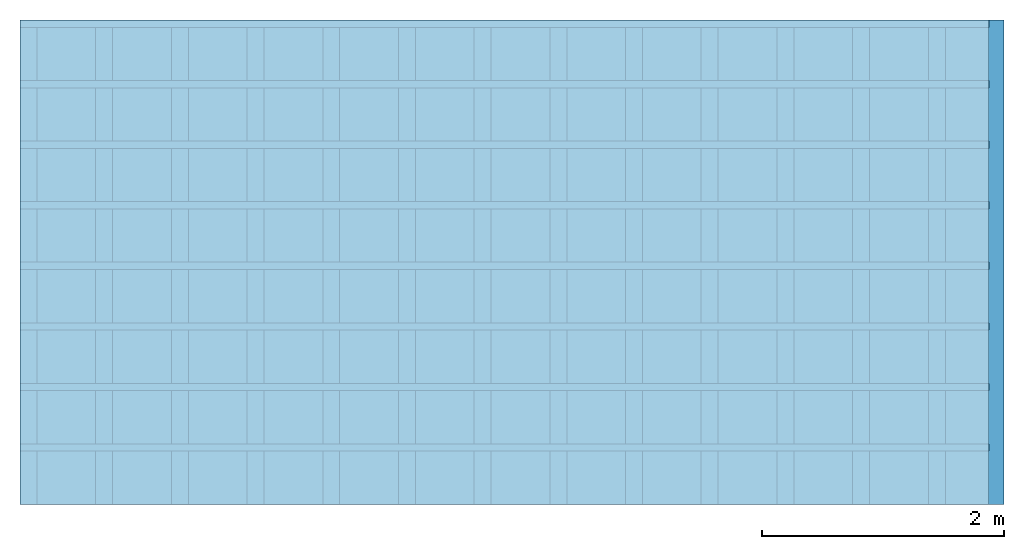
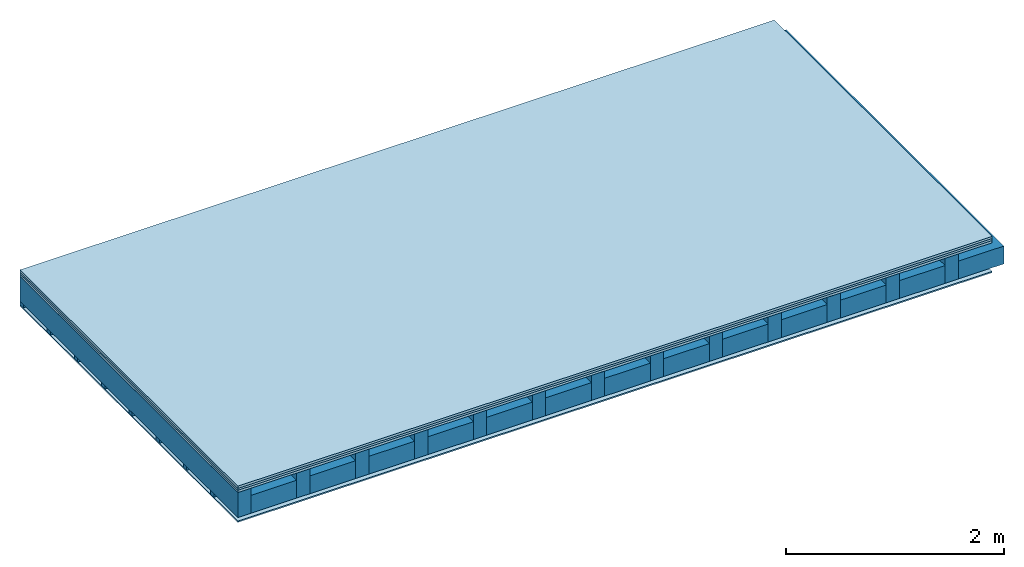
# One storey: 4 plates, 3 members, 1 element without a shape of its own.
"""IFC4 building model written with IfcOpenShell, lengths in metres."""

from ifc_helpers import new_model, si_unit, derived_unit, direction, frame, frame_2d, origin, origin_with_axes, place, context, project, spatial, rectangle, extrude, material, layer, layer_set, type_object, element, aggregate, save


model = new_model("IFC4")

# Units and contexts
plan_context = context("Plan", 3, precision=1e-05, world=origin(), true_north=direction((0.0, 1.0)))
model_context = context("Model", 3, precision=1e-05, world=origin(), true_north=direction((0.0, 1.0)))
ifc_project = project(units=[si_unit("LENGTHUNIT", "METRE"), derived_unit("SOUNDPRESSUREUNIT", [(si_unit("PRESSUREUNIT", "PASCAL", prefix="MICRO"), 0)]), si_unit("ENERGYUNIT", "JOULE", prefix="MEGA"), si_unit("MASSUNIT", "GRAM", prefix="KILO"), derived_unit("THERMALTRANSMITTANCEUNIT", [(si_unit("POWERUNIT", "WATT"), 1), (si_unit("AREAUNIT", "SQUARE_METRE"), -1), (si_unit("THERMODYNAMICTEMPERATUREUNIT", "KELVIN"), -1)]), derived_unit("AREADENSITYUNIT", [(si_unit("MASSUNIT", "GRAM", prefix="KILO"), 1), (si_unit("AREAUNIT", "SQUARE_METRE"), -1)]), derived_unit("USERDEFINED", [(si_unit("ENERGYUNIT", "JOULE", prefix="MEGA"), 1), (si_unit("AREAUNIT", "SQUARE_METRE"), -1)])], contexts=[plan_context, model_context])

# Site, building, storey
site = spatial("IfcSite", under=ifc_project)
building_placement = place(None, origin())
building = spatial("IfcBuilding", under=site, at=building_placement)
storey_placement = place(building_placement, origin())
storey = spatial("IfcBuildingStorey", under=building, at=storey_placement)

# Slab, members, plates
ifc_material_1 = material(Name="Floor heating system Therm38 longitudinal", Category="03.007")
ifc_layer_1 = layer(ifc_material_1, 0.025, Name="On-material")
ifc_material_2 = material(Category="10.009")
ifc_layer_2 = layer(ifc_material_2, 0.022, Name="Impact sound insulation")
ifc_material_3 = material(Category="07.001")
ifc_layer_3 = layer(ifc_material_3, 0.025, Name="Sub-floor")
ifc_material_4 = material(Name="of the art")
ifc_layer_4 = layer(ifc_material_4, 0.0, Name="Bond")
ifc_layer_5 = layer(None, 0.28, Name="Supporting structure")
ifc_layer_6 = layer(ifc_material_4, 0.0, Name="Bond")
ifc_layer_7 = layer(None, 0.04, Name="Battens / profiles")
ifc_material_5 = material(Category="03.007")
ifc_layer_8 = layer(ifc_material_5, 0.015, Name="Ceiling covering 1st layer")
ifc_material_6 = material(Name="Glued joints")
ifc_layer_9 = layer(ifc_material_6, 0.0, Name="Surface / treatment")
ifc_layer_set = layer_set([ifc_layer_1, ifc_layer_2, ifc_layer_3, ifc_layer_4, ifc_layer_5, ifc_layer_6, ifc_layer_7, ifc_layer_8, ifc_layer_9])
slab_type = type_object("IfcSlabType", Name="A0109", PredefinedType="NOTDEFINED", material=ifc_layer_set)
slab_placement = place(None, frame((0.0, 0.0, 0.0), z_axis=(0.0, 0.0, -1.0), x_axis=(1.0, 0.0, 0.0)))
slab = element("IfcSlab", 1, at=slab_placement, inside=storey, type_object=slab_type, material=ifc_layer_set, Name="Slab #1")
ifc_material_7 = material()
member_1_placement = place(slab_placement, origin())
member_1 = element("IfcMember", 2, at=member_1_placement, material=ifc_material_7, Name="Supporting structure", context=plan_context, shape_type="SweptSolid", body=[
    extrude(rectangle(XDim=0.14, YDim=0.28, at=frame_2d((0.07, 0.14), x_axis=(1.0, 0.0))), frame((0.0, 4.0, 0.072), z_axis=(0.0, -1.0, 0.0), x_axis=(1.0, 0.0, 0.0)), (0.0, 0.0, 1.0), 4.0),
    extrude(rectangle(XDim=0.14, YDim=0.28, at=frame_2d((0.07, 0.14), x_axis=(1.0, 0.0))), frame((0.625, 4.0, 0.072), z_axis=(0.0, -1.0, 0.0), x_axis=(1.0, 0.0, 0.0)), (0.0, 0.0, 1.0), 4.0),
    extrude(rectangle(XDim=0.14, YDim=0.28, at=frame_2d((0.07, 0.14), x_axis=(1.0, 0.0))), frame((1.25, 4.0, 0.072), z_axis=(0.0, -1.0, 0.0), x_axis=(1.0, 0.0, 0.0)), (0.0, 0.0, 1.0), 4.0),
    extrude(rectangle(XDim=0.14, YDim=0.28, at=frame_2d((0.07, 0.14), x_axis=(1.0, 0.0))), frame((1.875, 4.0, 0.072), z_axis=(0.0, -1.0, 0.0), x_axis=(1.0, 0.0, 0.0)), (0.0, 0.0, 1.0), 4.0),
    extrude(rectangle(XDim=0.14, YDim=0.28, at=frame_2d((0.07, 0.14), x_axis=(1.0, 0.0))), frame((2.5, 4.0, 0.072), z_axis=(0.0, -1.0, 0.0), x_axis=(1.0, 0.0, 0.0)), (0.0, 0.0, 1.0), 4.0),
    extrude(rectangle(XDim=0.14, YDim=0.28, at=frame_2d((0.07, 0.14), x_axis=(1.0, 0.0))), frame((3.125, 4.0, 0.072), z_axis=(0.0, -1.0, 0.0), x_axis=(1.0, 0.0, 0.0)), (0.0, 0.0, 1.0), 4.0),
    extrude(rectangle(XDim=0.14, YDim=0.28, at=frame_2d((0.07, 0.14), x_axis=(1.0, 0.0))), frame((3.75, 4.0, 0.072), z_axis=(0.0, -1.0, 0.0), x_axis=(1.0, 0.0, 0.0)), (0.0, 0.0, 1.0), 4.0),
    extrude(rectangle(XDim=0.14, YDim=0.28, at=frame_2d((0.07, 0.14), x_axis=(1.0, 0.0))), frame((4.375, 4.0, 0.072), z_axis=(0.0, -1.0, 0.0), x_axis=(1.0, 0.0, 0.0)), (0.0, 0.0, 1.0), 4.0),
    extrude(rectangle(XDim=0.14, YDim=0.28, at=frame_2d((0.07, 0.14), x_axis=(1.0, 0.0))), frame((5.0, 4.0, 0.072), z_axis=(0.0, -1.0, 0.0), x_axis=(1.0, 0.0, 0.0)), (0.0, 0.0, 1.0), 4.0),
    extrude(rectangle(XDim=0.14, YDim=0.28, at=frame_2d((0.07, 0.14), x_axis=(1.0, 0.0))), frame((5.625, 4.0, 0.072), z_axis=(0.0, -1.0, 0.0), x_axis=(1.0, 0.0, 0.0)), (0.0, 0.0, 1.0), 4.0),
    extrude(rectangle(XDim=0.14, YDim=0.28, at=frame_2d((0.07, 0.14), x_axis=(1.0, 0.0))), frame((6.25, 4.0, 0.072), z_axis=(0.0, -1.0, 0.0), x_axis=(1.0, 0.0, 0.0)), (0.0, 0.0, 1.0), 4.0),
    extrude(rectangle(XDim=0.14, YDim=0.28, at=frame_2d((0.07, 0.14), x_axis=(1.0, 0.0))), frame((6.875, 4.0, 0.072), z_axis=(0.0, -1.0, 0.0), x_axis=(1.0, 0.0, 0.0)), (0.0, 0.0, 1.0), 4.0),
    extrude(rectangle(XDim=0.14, YDim=0.28, at=frame_2d((0.07, 0.14), x_axis=(1.0, 0.0))), frame((7.5, 4.0, 0.072), z_axis=(0.0, -1.0, 0.0), x_axis=(1.0, 0.0, 0.0)), (0.0, 0.0, 1.0), 4.0),
])
ifc_material_8 = material()
member_2_placement = place(slab_placement, origin())
member_2 = element("IfcMember", 3, at=member_2_placement, material=ifc_material_8, Name="Cavity", context=plan_context, shape_type="SweptSolid", body=[
    extrude(rectangle(XDim=0.485, YDim=0.2, at=frame_2d((0.2425, 0.1), x_axis=(1.0, 0.0))), frame((0.14, 4.0, 0.152), z_axis=(0.0, -1.0, 0.0), x_axis=(1.0, 0.0, 0.0)), (0.0, 0.0, 1.0), 4.0),
    extrude(rectangle(XDim=0.485, YDim=0.2, at=frame_2d((0.2425, 0.1), x_axis=(1.0, 0.0))), frame((0.765, 4.0, 0.152), z_axis=(0.0, -1.0, 0.0), x_axis=(1.0, 0.0, 0.0)), (0.0, 0.0, 1.0), 4.0),
    extrude(rectangle(XDim=0.485, YDim=0.2, at=frame_2d((0.2425, 0.1), x_axis=(1.0, 0.0))), frame((1.39, 4.0, 0.152), z_axis=(0.0, -1.0, 0.0), x_axis=(1.0, 0.0, 0.0)), (0.0, 0.0, 1.0), 4.0),
    extrude(rectangle(XDim=0.485, YDim=0.2, at=frame_2d((0.2425, 0.1), x_axis=(1.0, 0.0))), frame((2.015, 4.0, 0.152), z_axis=(0.0, -1.0, 0.0), x_axis=(1.0, 0.0, 0.0)), (0.0, 0.0, 1.0), 4.0),
    extrude(rectangle(XDim=0.485, YDim=0.2, at=frame_2d((0.2425, 0.1), x_axis=(1.0, 0.0))), frame((2.64, 4.0, 0.152), z_axis=(0.0, -1.0, 0.0), x_axis=(1.0, 0.0, 0.0)), (0.0, 0.0, 1.0), 4.0),
    extrude(rectangle(XDim=0.485, YDim=0.2, at=frame_2d((0.2425, 0.1), x_axis=(1.0, 0.0))), frame((3.265, 4.0, 0.152), z_axis=(0.0, -1.0, 0.0), x_axis=(1.0, 0.0, 0.0)), (0.0, 0.0, 1.0), 4.0),
    extrude(rectangle(XDim=0.485, YDim=0.2, at=frame_2d((0.2425, 0.1), x_axis=(1.0, 0.0))), frame((3.89, 4.0, 0.152), z_axis=(0.0, -1.0, 0.0), x_axis=(1.0, 0.0, 0.0)), (0.0, 0.0, 1.0), 4.0),
    extrude(rectangle(XDim=0.485, YDim=0.2, at=frame_2d((0.2425, 0.1), x_axis=(1.0, 0.0))), frame((4.515, 4.0, 0.152), z_axis=(0.0, -1.0, 0.0), x_axis=(1.0, 0.0, 0.0)), (0.0, 0.0, 1.0), 4.0),
    extrude(rectangle(XDim=0.485, YDim=0.2, at=frame_2d((0.2425, 0.1), x_axis=(1.0, 0.0))), frame((5.14, 4.0, 0.152), z_axis=(0.0, -1.0, 0.0), x_axis=(1.0, 0.0, 0.0)), (0.0, 0.0, 1.0), 4.0),
    extrude(rectangle(XDim=0.485, YDim=0.2, at=frame_2d((0.2425, 0.1), x_axis=(1.0, 0.0))), frame((5.765, 4.0, 0.152), z_axis=(0.0, -1.0, 0.0), x_axis=(1.0, 0.0, 0.0)), (0.0, 0.0, 1.0), 4.0),
    extrude(rectangle(XDim=0.485, YDim=0.2, at=frame_2d((0.2425, 0.1), x_axis=(1.0, 0.0))), frame((6.39, 4.0, 0.152), z_axis=(0.0, -1.0, 0.0), x_axis=(1.0, 0.0, 0.0)), (0.0, 0.0, 1.0), 4.0),
    extrude(rectangle(XDim=0.485, YDim=0.2, at=frame_2d((0.2425, 0.1), x_axis=(1.0, 0.0))), frame((7.015, 4.0, 0.152), z_axis=(0.0, -1.0, 0.0), x_axis=(1.0, 0.0, 0.0)), (0.0, 0.0, 1.0), 4.0),
    extrude(rectangle(XDim=0.485, YDim=0.2, at=frame_2d((0.2425, 0.1), x_axis=(1.0, 0.0))), frame((7.64, 4.0, 0.152), z_axis=(0.0, -1.0, 0.0), x_axis=(1.0, 0.0, 0.0)), (0.0, 0.0, 1.0), 4.0),
])
ifc_material_9 = material()
member_3_placement = place(slab_placement, origin())
member_3 = element("IfcMember", 4, at=member_3_placement, material=ifc_material_9, Name="Battens / profiles", context=plan_context, shape_type="SweptSolid", body=[
    extrude(rectangle(XDim=0.06, YDim=0.04, at=frame_2d((0.03, 0.02), x_axis=(1.0, 0.0))), frame((0.0, 0.0, 0.352), z_axis=(1.0, 0.0, 0.0), x_axis=(0.0, 1.0, 0.0)), (0.0, 0.0, 1.0), 8.0),
    extrude(rectangle(XDim=0.06, YDim=0.04, at=frame_2d((0.03, 0.02), x_axis=(1.0, 0.0))), frame((0.0, 0.5, 0.352), z_axis=(1.0, 0.0, 0.0), x_axis=(0.0, 1.0, 0.0)), (0.0, 0.0, 1.0), 8.0),
    extrude(rectangle(XDim=0.06, YDim=0.04, at=frame_2d((0.03, 0.02), x_axis=(1.0, 0.0))), frame((0.0, 1.0, 0.352), z_axis=(1.0, 0.0, 0.0), x_axis=(0.0, 1.0, 0.0)), (0.0, 0.0, 1.0), 8.0),
    extrude(rectangle(XDim=0.06, YDim=0.04, at=frame_2d((0.03, 0.02), x_axis=(1.0, 0.0))), frame((0.0, 1.5, 0.352), z_axis=(1.0, 0.0, 0.0), x_axis=(0.0, 1.0, 0.0)), (0.0, 0.0, 1.0), 8.0),
    extrude(rectangle(XDim=0.06, YDim=0.04, at=frame_2d((0.03, 0.02), x_axis=(1.0, 0.0))), frame((0.0, 2.0, 0.352), z_axis=(1.0, 0.0, 0.0), x_axis=(0.0, 1.0, 0.0)), (0.0, 0.0, 1.0), 8.0),
    extrude(rectangle(XDim=0.06, YDim=0.04, at=frame_2d((0.03, 0.02), x_axis=(1.0, 0.0))), frame((0.0, 2.5, 0.352), z_axis=(1.0, 0.0, 0.0), x_axis=(0.0, 1.0, 0.0)), (0.0, 0.0, 1.0), 8.0),
    extrude(rectangle(XDim=0.06, YDim=0.04, at=frame_2d((0.03, 0.02), x_axis=(1.0, 0.0))), frame((0.0, 3.0, 0.352), z_axis=(1.0, 0.0, 0.0), x_axis=(0.0, 1.0, 0.0)), (0.0, 0.0, 1.0), 8.0),
    extrude(rectangle(XDim=0.06, YDim=0.04, at=frame_2d((0.03, 0.02), x_axis=(1.0, 0.0))), frame((0.0, 3.5, 0.352), z_axis=(1.0, 0.0, 0.0), x_axis=(0.0, 1.0, 0.0)), (0.0, 0.0, 1.0), 8.0),
])
plate_1_placement = place(slab_placement, origin())
plate_1 = element("IfcPlate", 5, at=plate_1_placement, material=ifc_material_1, Name="On-material", context=plan_context, shape_type="SweptSolid", body=[
    extrude(rectangle(XDim=8.0, YDim=4.0, at=frame_2d((4.0, 2.0), x_axis=(1.0, 0.0))), origin_with_axes(), (0.0, 0.0, 1.0), 0.025),
])
plate_2_placement = place(slab_placement, origin())
plate_2 = element("IfcPlate", 6, at=plate_2_placement, material=ifc_material_2, Name="Impact sound insulation", context=plan_context, shape_type="SweptSolid", body=[
    extrude(rectangle(XDim=8.0, YDim=4.0, at=frame_2d((4.0, 2.0), x_axis=(1.0, 0.0))), frame((0.0, 0.0, 0.025), z_axis=(0.0, 0.0, 1.0), x_axis=(1.0, 0.0, 0.0)), (0.0, 0.0, 1.0), 0.022),
])
plate_3_placement = place(slab_placement, origin())
plate_3 = element("IfcPlate", 7, at=plate_3_placement, material=ifc_material_3, Name="Sub-floor", context=plan_context, shape_type="SweptSolid", body=[
    extrude(rectangle(XDim=8.0, YDim=4.0, at=frame_2d((4.0, 2.0), x_axis=(1.0, 0.0))), frame((0.0, 0.0, 0.047), z_axis=(0.0, 0.0, 1.0), x_axis=(1.0, 0.0, 0.0)), (0.0, 0.0, 1.0), 0.025),
])
plate_4_placement = place(slab_placement, origin())
plate_4 = element("IfcPlate", 8, at=plate_4_placement, material=ifc_material_5, Name="Ceiling covering 1st layer", context=plan_context, shape_type="SweptSolid", body=[
    extrude(rectangle(XDim=8.0, YDim=4.0, at=frame_2d((4.0, 2.0), x_axis=(1.0, 0.0))), frame((0.0, 0.0, 0.392), z_axis=(0.0, 0.0, 1.0), x_axis=(1.0, 0.0, 0.0)), (0.0, 0.0, 1.0), 0.015),
])
aggregate(slab, [plate_1, plate_2, plate_3, member_1, member_2, member_3, plate_4])

save(model, "model.ifc")
